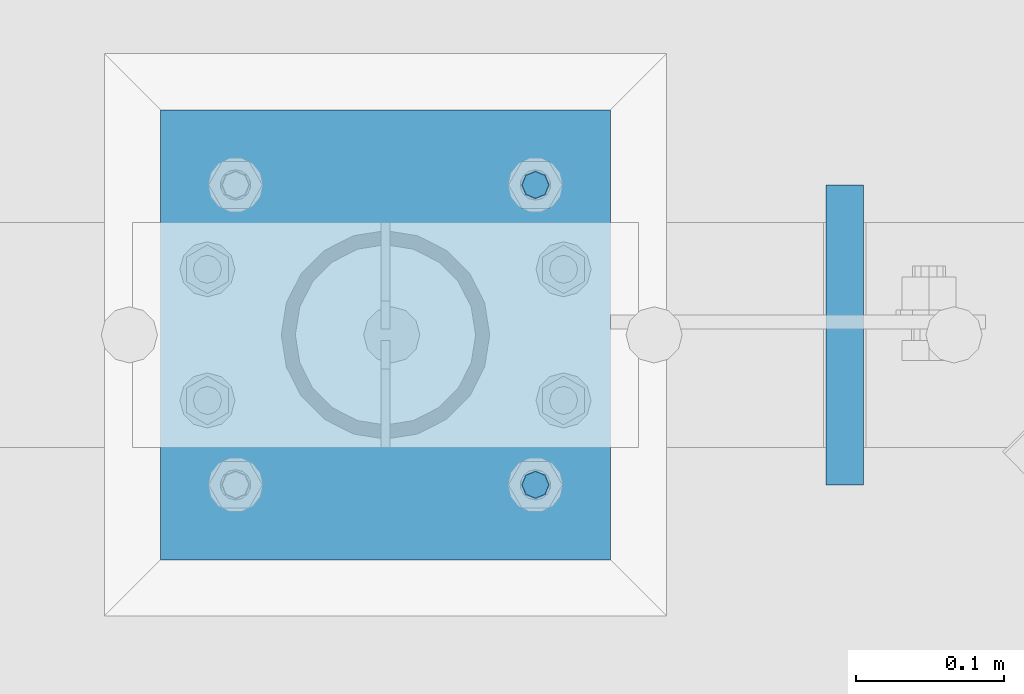
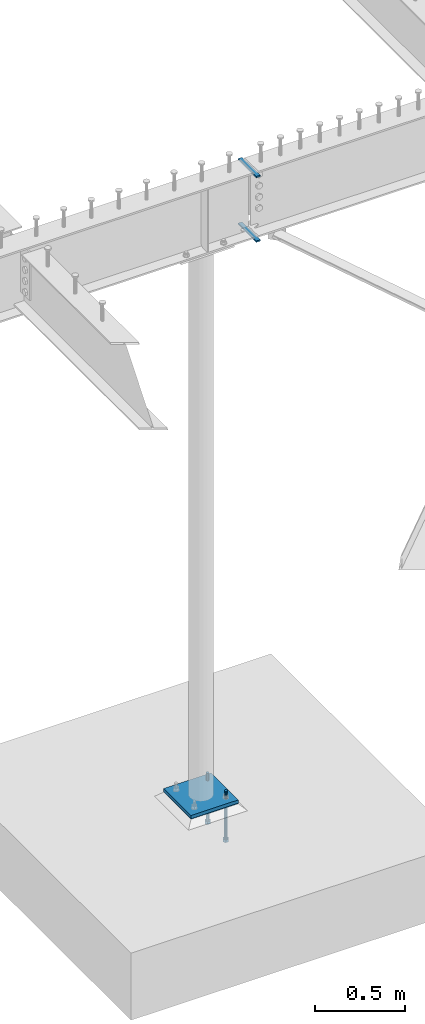
# One storey, part 416 of 975: 6 beams.
"""IFC2X3 building model written with IfcOpenShell, lengths in millimetres."""

from ifc_helpers import new_model, si_unit, frame, origin_with_axes, place, context, subcontext, project, spatial, faceted_brep, material, type_object, element, save


model = new_model("IFC2X3")

# Units and contexts
model_context = context("Model", 3, precision=1e-05, world=origin_with_axes())
body_context = subcontext(model_context, "Body", "Model", "MODEL_VIEW")
ifc_project = project(units=[si_unit("LENGTHUNIT", "METRE", prefix="MILLI"), si_unit("AREAUNIT", "SQUARE_METRE"), si_unit("VOLUMEUNIT", "CUBIC_METRE"), si_unit("MASSUNIT", "GRAM", prefix="KILO"), si_unit("TIMEUNIT", "SECOND"), si_unit("PLANEANGLEUNIT", "RADIAN"), si_unit("SOLIDANGLEUNIT", "STERADIAN"), si_unit("THERMODYNAMICTEMPERATUREUNIT", "DEGREE_CELSIUS"), si_unit("LUMINOUSINTENSITYUNIT", "LUMEN")], contexts=[model_context])

# Site, building, storey
site_placement = place(None, origin_with_axes())
site = spatial("IfcSite", under=ifc_project, at=site_placement, CompositionType="ELEMENT")
building_placement = place(site_placement, origin_with_axes())
building = spatial("IfcBuilding", under=site, at=building_placement, Name="Undefined", CompositionType="ELEMENT")
storey_placement = place(building_placement, origin_with_axes())
storey = spatial("IfcBuildingStorey", under=building, at=storey_placement, Name="Undefined", CompositionType="ELEMENT", Elevation=0.0)

# Beams
ifc_material_1 = material(Name="STEEL/A36")
beam_type_1 = type_object("IfcBeamType", PredefinedType="NOTDEFINED")
for number, where, z_axis, x_axis, name in (
    (1, (25036.4625312948, 13290.55, 3481.3875), (-0.999999999999998, 6.90000001668524e-08, 0.0), (0.0, 1.0, 0.0), "FLAT BAR"),
    (2, (25036.4625312948, 13290.55, 3921.1245), (-0.999999999999998, 6.90000001668524e-08, 0.0), (0.0, 1.0, 0.0), "FLAT BAR"),
):
    element("IfcBeam", number, at=place(storey_placement, frame(where, z_axis=z_axis, x_axis=x_axis)), inside=storey, type_object=beam_type_1, material=ifc_material_1, Name=name, context=body_context, shape_type="Brep", body=[
        faceted_brep([(7.27595761418343e-12, 4.76249999999982, -12.6999999999698), (-3.15558281727135e-08, 4.76249999999936, 12.6999998092651), (203.199999999022, 4.76249999999982, 12.6999999999716), (203.199999999022, 4.76249999999982, -12.6999999999662), (-3.15667421091348e-08, -4.76250000000027, 12.6999998092651), (203.199999999022, -4.76249999999982, 12.6999999999716), (7.27595761418343e-12, -4.76249999999982, -12.6999999999698), (203.199999999022, -4.76249999999982, -12.6999999999662)], [[[0, 1, 2, 3]], [[1, 4, 5, 2]], [[4, 6, 7, 5]], [[6, 0, 3, 7]], [[5, 7, 3, 2]], [[6, 4, 1, 0]]]),
    ])
ifc_material_2 = material(Name="STEEL/F1554-36")
beam_type_2 = type_object("IfcBeamType", PredefinedType="NOTDEFINED")
beam_1_placement = place(storey_placement, frame((24826.9124984741, 13493.75, -304.799999999999), z_axis=(0.0, -1.0, 0.0), x_axis=(0.0, 0.0, -1.0)))
element("IfcBeam", 3, at=beam_1_placement, inside=storey, type_object=beam_type_2, material=ifc_material_2, Name="HEADED_ANCHOR_BOLT", context=body_context, shape_type="Brep", body=[
    faceted_brep([(210.34375, -9.13000011444637, 15.8100004196167), (210.34375, -18.2600002288873, 0.0), (229.393749999999, -18.2600002288873, 0.0), (229.393749999999, -9.13000011444637, 15.8100004196167), (210.34375, 9.13000011443546, 15.8100004196167), (229.393749999999, 9.13000011443546, 15.8100004196167), (210.34375, 18.2600002288764, 0.0), (229.393749999999, 18.2600002288764, 0.0), (210.34375, 9.13000011443546, -15.8100004196167), (229.393749999999, 9.13000011443546, -15.8100004196167), (210.34375, -9.13000011444637, -15.8100004196167), (229.393749999999, -9.13000011444637, -15.8100004196167), (210.34375, -4.47768005528815, 9.29799844179888), (210.34375, -8.06850066047991, 6.43441456490837), (210.34375, -10.0612557561972, 2.29641597052159), (210.34375, -10.0612557561972, -2.29641597052159), (210.34375, -8.06850066047991, -6.43441456490837), (210.34375, -4.47768005528815, -9.29799844179888), (210.34375, -5.45696821063757e-12, -10.3199996948242), (210.34375, 4.47768005527723, -9.29799844179888), (210.34375, 8.068500660469, -6.43441456490837), (210.34375, 10.0612557561863, -2.29641597052159), (210.34375, 10.0612557561863, 2.29641597052159), (210.34375, 8.068500660469, 6.43441456490837), (210.34375, 4.47768005527723, 9.29799844179888), (210.34375, -5.45696821063757e-12, 10.3199996948242), (229.393749999999, -5.45696821063757e-12, 10.3199996948242), (229.393749999999, -4.47768005528815, 9.29799844179888), (229.393749999999, -8.06850066047991, 6.43441456490837), (229.393749999999, -10.0612557561972, 2.29641597052159), (229.393749999999, -10.0612557561972, -2.29641597052159), (229.393749999999, -8.06850066047991, -6.43441456490837), (229.393749999999, -4.47768005528815, -9.29799844179888), (229.393749999999, -5.45696821063757e-12, -10.3199996948242), (229.393749999999, 4.47768005527723, -9.29799844179888), (229.393749999999, 8.068500660469, -6.43441456490837), (229.393749999999, 10.0612557561863, -2.29641597052159), (229.393749999999, 10.0612557561863, 2.29641597052159), (229.393749999999, 8.068500660469, 6.43441456490837), (229.393749999999, 4.47768005527723, 9.29799844179888), (0.0, -6.73519209080223, 6.73519209080186), (0.0, -9.52499999999964, 0.0), (228.6, -9.52500000000146, 0.0), (228.6, -6.73519209080405, 6.73519209080223), (-9.87109982941227e-13, -1.20792265079217e-13, 9.52499961853027), (228.6, 0.0, 9.52499999999964), (0.0, 6.73519209080223, 6.73519209080186), (228.6, 6.73519209080405, 6.73519209080223), (0.0, 9.52499999999964, 0.0), (228.6, 9.52500000000146, 0.0), (0.0, 6.73519209080223, -6.73519209080186), (228.6, 6.73519209080405, -6.73519209080223), (2.95075507493764e-12, -1.20792265079217e-13, -9.52499961853027), (228.6, 0.0, -9.52499999999964), (-114.293750057273, -6.36396001342564, 6.36396103067909), (-114.293749999997, 1.01725345302839e-06, 9.0), (-114.293749942721, 6.36396204793255, 6.36396103067909), (-114.293749918997, 9.00000101725345, 0.0), (-114.293749942721, 6.36396204793255, -6.36396103067909), (-114.293749999997, 1.01725345302839e-06, -9.0), (-114.293750057273, -6.36396001342564, -6.36396103067909), (-114.293750080997, -8.99999898274655, 0.0), (0.00625005727778216, 6.36396101919127, -6.36396103067909), (0.00625000000218279, -1.14878275780939e-08, -9.0), (0.00624994272658341, -6.36396104216692, -6.36396103067909), (0.00624991900230043, -9.00000001148783, 0.0), (0.00624994272658341, -6.36396104216692, 6.36396103067909), (0.00625000000218279, -1.14878275780939e-08, 9.0), (0.00625005727778216, 6.36396101919127, 6.36396103067909), (0.00625008100212199, 8.99999998851217, 0.0), (0.0, -6.73519209080223, -6.73519209080186), (228.6, -6.73519209080405, -6.73519209080223)], [[[0, 1, 2, 3]], [[4, 0, 3, 5]], [[6, 4, 5, 7]], [[8, 6, 7, 9]], [[10, 8, 9, 11]], [[0, 4, 6, 8, 10, 1], [12, 13, 14, 15, 16, 17, 18, 19, 20, 21, 22, 23, 24, 25]], [[12, 25, 26, 27]], [[13, 12, 27, 28]], [[14, 13, 28, 29]], [[15, 14, 29, 30]], [[16, 15, 30, 31]], [[17, 16, 31, 32]], [[18, 17, 32, 33]], [[19, 18, 33, 34]], [[20, 19, 34, 35]], [[21, 20, 35, 36]], [[22, 21, 36, 37]], [[23, 22, 37, 38]], [[24, 23, 38, 39]], [[25, 24, 39, 26]], [[9, 7, 5, 3, 2, 11], [38, 37, 36, 35, 34, 33, 32, 31, 30, 29, 28, 27, 26, 39]], [[1, 10, 11, 2]], [[40, 41, 42, 43]], [[44, 40, 43, 45]], [[46, 44, 45, 47]], [[48, 46, 47, 49]], [[50, 48, 49, 51]], [[52, 50, 51, 53]], [[54, 55, 56, 57, 58, 59, 60, 61]], [[59, 58, 62, 63]], [[60, 59, 63, 64]], [[61, 60, 64, 65]], [[54, 61, 65, 66]], [[55, 54, 66, 67]], [[56, 55, 67, 68]], [[57, 56, 68, 69]], [[58, 57, 69, 62]], [[40, 44, 46, 48, 50, 52, 70, 41], [68, 67, 66, 65, 64, 63, 62, 69]], [[41, 70, 71, 42]], [[53, 51, 49, 47, 45, 43, 42, 71]], [[70, 52, 53, 71]]]),
])
beam_2_placement = place(storey_placement, frame((24826.9124984741, 13290.5500030518, -304.799999999999), z_axis=(0.0, -1.0, 0.0), x_axis=(0.0, 0.0, -1.0)))
element("IfcBeam", 4, at=beam_2_placement, inside=storey, type_object=beam_type_2, material=ifc_material_2, Name="HEADED_ANCHOR_BOLT", context=body_context, shape_type="Brep", body=[
    faceted_brep([(210.34375, -9.13000011444637, 15.8100004196167), (210.34375, -18.2600002288873, 0.0), (229.393749999999, -18.2600002288873, 0.0), (229.393749999999, -9.13000011444637, 15.8100004196167), (210.34375, 9.13000011443546, 15.8100004196167), (229.393749999999, 9.13000011443546, 15.8100004196167), (210.34375, 18.2600002288764, 0.0), (229.393749999999, 18.2600002288764, 0.0), (210.34375, 9.13000011443546, -15.8100004196167), (229.393749999999, 9.13000011443546, -15.8100004196167), (210.34375, -9.13000011444637, -15.8100004196167), (229.393749999999, -9.13000011444637, -15.8100004196167), (210.34375, -4.47768005528815, 9.29799844179888), (210.34375, -8.06850066047991, 6.43441456490837), (210.34375, -10.0612557561972, 2.29641597052159), (210.34375, -10.0612557561972, -2.29641597052159), (210.34375, -8.06850066047991, -6.43441456490837), (210.34375, -4.47768005528815, -9.29799844179888), (210.34375, -5.45696821063757e-12, -10.3199996948242), (210.34375, 4.47768005527723, -9.29799844179888), (210.34375, 8.068500660469, -6.43441456490837), (210.34375, 10.0612557561863, -2.29641597052159), (210.34375, 10.0612557561863, 2.29641597052159), (210.34375, 8.068500660469, 6.43441456490837), (210.34375, 4.47768005527723, 9.29799844179888), (210.34375, -5.45696821063757e-12, 10.3199996948242), (229.393749999999, -5.45696821063757e-12, 10.3199996948242), (229.393749999999, -4.47768005528815, 9.29799844179888), (229.393749999999, -8.06850066047991, 6.43441456490837), (229.393749999999, -10.0612557561972, 2.29641597052159), (229.393749999999, -10.0612557561972, -2.29641597052159), (229.393749999999, -8.06850066047991, -6.43441456490837), (229.393749999999, -4.47768005528815, -9.29799844179888), (229.393749999999, -5.45696821063757e-12, -10.3199996948242), (229.393749999999, 4.47768005527723, -9.29799844179888), (229.393749999999, 8.068500660469, -6.43441456490837), (229.393749999999, 10.0612557561863, -2.29641597052159), (229.393749999999, 10.0612557561863, 2.29641597052159), (229.393749999999, 8.068500660469, 6.43441456490837), (229.393749999999, 4.47768005527723, 9.29799844179888), (0.0, -6.73519209080223, 6.73519209080186), (0.0, -9.52499999999964, 0.0), (228.6, -9.52500000000146, 0.0), (228.6, -6.73519209080405, 6.73519209080223), (-9.87109982941227e-13, -1.20792265079217e-13, 9.52499961853027), (228.6, 0.0, 9.52499999999964), (0.0, 6.73519209080223, 6.73519209080186), (228.6, 6.73519209080405, 6.73519209080223), (0.0, 9.52499999999964, 0.0), (228.6, 9.52500000000146, 0.0), (0.0, 6.73519209080223, -6.73519209080186), (228.6, 6.73519209080405, -6.73519209080223), (2.95075507493764e-12, -1.20792265079217e-13, -9.52499961853027), (228.6, 0.0, -9.52499999999964), (-114.293750057273, -6.36396001342564, 6.36396103067909), (-114.293749999997, 1.01725345302839e-06, 9.0), (-114.293749942721, 6.36396204793255, 6.36396103067909), (-114.293749918997, 9.00000101725345, 0.0), (-114.293749942721, 6.36396204793255, -6.36396103067909), (-114.293749999997, 1.01725345302839e-06, -9.0), (-114.293750057273, -6.36396001342564, -6.36396103067909), (-114.293750080997, -8.99999898274655, 0.0), (0.00625005727778216, 6.36396101919127, -6.36396103067909), (0.00625000000218279, -1.14878275780939e-08, -9.0), (0.00624994272658341, -6.36396104216692, -6.36396103067909), (0.00624991900230043, -9.00000001148783, 0.0), (0.00624994272658341, -6.36396104216692, 6.36396103067909), (0.00625000000218279, -1.14878275780939e-08, 9.0), (0.00625005727778216, 6.36396101919127, 6.36396103067909), (0.00625008100212199, 8.99999998851217, 0.0), (0.0, -6.73519209080223, -6.73519209080186), (228.6, -6.73519209080405, -6.73519209080223)], [[[0, 1, 2, 3]], [[4, 0, 3, 5]], [[6, 4, 5, 7]], [[8, 6, 7, 9]], [[10, 8, 9, 11]], [[0, 4, 6, 8, 10, 1], [12, 13, 14, 15, 16, 17, 18, 19, 20, 21, 22, 23, 24, 25]], [[12, 25, 26, 27]], [[13, 12, 27, 28]], [[14, 13, 28, 29]], [[15, 14, 29, 30]], [[16, 15, 30, 31]], [[17, 16, 31, 32]], [[18, 17, 32, 33]], [[19, 18, 33, 34]], [[20, 19, 34, 35]], [[21, 20, 35, 36]], [[22, 21, 36, 37]], [[23, 22, 37, 38]], [[24, 23, 38, 39]], [[25, 24, 39, 26]], [[9, 7, 5, 3, 2, 11], [38, 37, 36, 35, 34, 33, 32, 31, 30, 29, 28, 27, 26, 39]], [[1, 10, 11, 2]], [[40, 41, 42, 43]], [[44, 40, 43, 45]], [[46, 44, 45, 47]], [[48, 46, 47, 49]], [[50, 48, 49, 51]], [[52, 50, 51, 53]], [[54, 55, 56, 57, 58, 59, 60, 61]], [[59, 58, 62, 63]], [[60, 59, 63, 64]], [[61, 60, 64, 65]], [[54, 61, 65, 66]], [[55, 54, 66, 67]], [[56, 55, 67, 68]], [[57, 56, 68, 69]], [[58, 57, 69, 62]], [[40, 44, 46, 48, 50, 52, 70, 41], [68, 67, 66, 65, 64, 63, 62, 69]], [[41, 70, 71, 42]], [[53, 51, 49, 47, 45, 43, 42, 71]], [[70, 52, 53, 71]]]),
])
beam_type_3 = type_object("IfcBeamType", PredefinedType="NOTDEFINED")
beam_3_placement = place(storey_placement, frame((24725.3125, 13239.75, -265.112500000001), z_axis=(-0.999999999999998, 6.90000001668524e-08, 0.0), x_axis=(0.0, 1.0, 0.0)))
element("IfcBeam", 5, at=beam_3_placement, inside=storey, type_object=beam_type_3, material=ifc_material_1, Name="TEMPLATE", context=body_context, shape_type="Brep", body=[
    faceted_brep([(0.0, 1.58750000000009, -152.4), (0.0, 1.58750000000009, 152.4), (304.799999999153, 1.58750000000001, 152.400000000001), (304.799999999153, 1.58750000000001, -152.400000000001), (0.0, -1.58750000000009, 152.4), (304.799999999153, -1.58750000000001, 152.400000000001), (0.0, -1.58750000000009, -152.4), (304.799999999153, -1.58750000000001, -152.400000000001)], [[[0, 1, 2, 3]], [[1, 4, 5, 2]], [[4, 6, 7, 5]], [[6, 0, 3, 7]], [[5, 7, 3, 2]], [[6, 4, 1, 0]]]),
])
beam_type_4 = type_object("IfcBeamType", PredefinedType="NOTDEFINED")
beam_4_placement = place(storey_placement, frame((24725.3125, 13239.75, -254.0), z_axis=(-0.999999999999998, 6.90000001668524e-08, 0.0), x_axis=(0.0, 1.0, 0.0)))
element("IfcBeam", 6, at=beam_4_placement, inside=storey, type_object=beam_type_4, material=ifc_material_1, Name="PLATE", context=body_context, shape_type="Brep", body=[
    faceted_brep([(0.0, 12.7, -152.400000000001), (-1.36424205265939e-12, 12.7, 152.400009155273), (304.800000000003, 12.7, 152.400000000001), (304.800000000003, 12.7, -152.400000000001), (0.0, -12.7, 152.400000000001), (304.800000000003, -12.7, 152.400000000001), (0.0, -12.7, -152.400000000001), (304.800000000003, -12.7, -152.400000000001)], [[[0, 1, 2, 3]], [[1, 4, 5, 2]], [[4, 6, 7, 5]], [[6, 0, 3, 7]], [[5, 7, 3, 2]], [[6, 4, 1, 0]]]),
])

save(model, "model.ifc")
